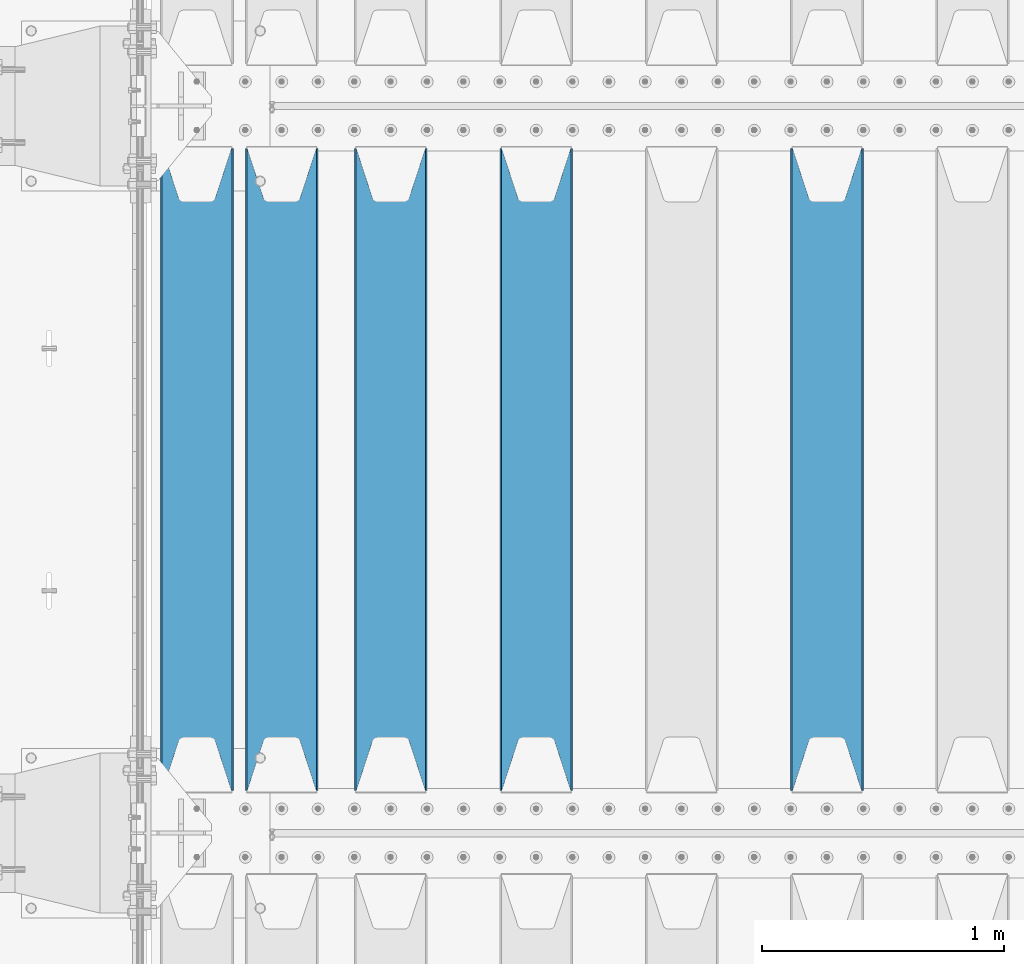
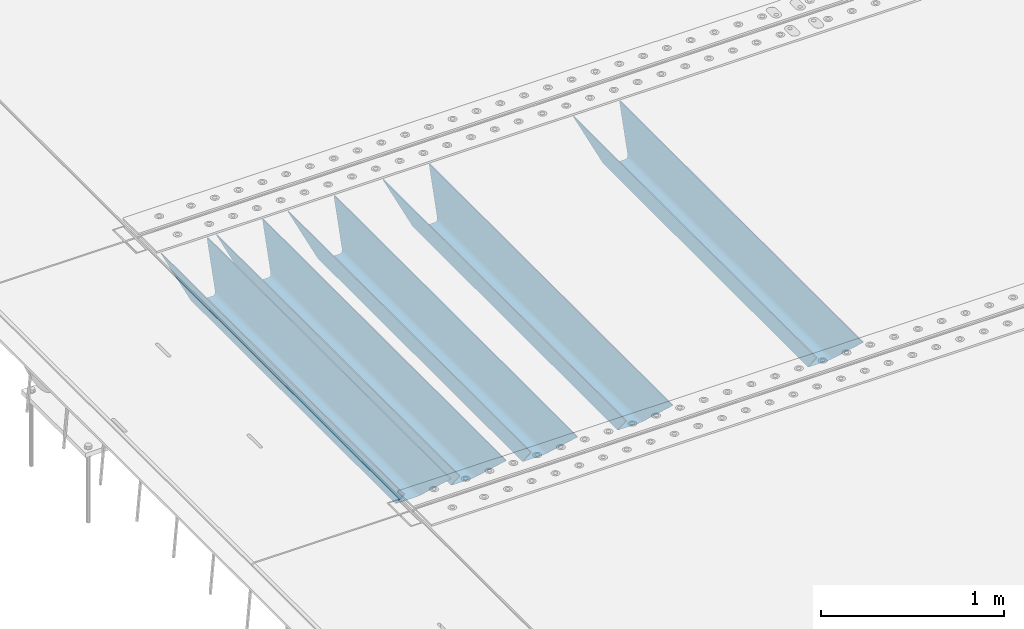
# One storey, part 102 of 240: 5 beams.
"""IFC2X3 building model written with IfcOpenShell, lengths in millimetres."""

import ifcopenshell
import ifcopenshell.guid

model = None  # the IFC model being written
_history = None  # IfcOwnerHistory: only IFC2X3 demands one
_inside = {}  # id of a spatial element -> (the spatial element, [elements in it])
_under = {}  # id of a project, library or spatial element -> (it, [spatial elements below it])
_declared = {}  # id of a project -> (the project, [libraries it declares])
_typed = {}  # id of a type object -> (the type object, [elements of that type])
_made_of = {}  # id of a material, layer set ... -> (it, [elements and type objects made of it])


def new_model(schema):
    """Start an empty IFC model of exactly this schema.

    Asked for "IFC4X3", IfcOpenShell would pick the latest addendum, in which some entities
    have other attributes; the version numbers below select the first issue.
    IFC2X3 requires an IfcOwnerHistory on every rooted entity: one is made here for all.
    """
    global model, _history
    if schema == "IFC4X3":
        model = ifcopenshell.file(schema_version=(4, 3, 0, 0))
    else:
        model = ifcopenshell.file(schema=schema)
    _inside.clear()
    _under.clear()
    _declared.clear()
    _typed.clear()
    _made_of.clear()
    _history = None
    if model.schema == "IFC2X3":
        org = make("IfcOrganization", Name="unknown")
        user = make(
            "IfcPersonAndOrganization",
            ThePerson=make("IfcPerson", FamilyName="unknown"),
            TheOrganization=org,
        )
        app = make(
            "IfcApplication",
            ApplicationDeveloper=org,
            Version="unknown",
            ApplicationFullName="unknown",
            ApplicationIdentifier="unknown",
        )
        _history = make(
            "IfcOwnerHistory",
            OwningUser=user,
            OwningApplication=app,
            ChangeAction="ADDED",
            CreationDate=0,
        )
    return model


def make(cls, **values):
    """One entity of the class cls with the attributes given. An attribute that is None is left unset."""
    return model.create_entity(
        cls, **{name: value for name, value in values.items() if value is not None}
    )


def rooted(cls, **values):
    """An entity with a GlobalId (a new one), such as an element, a storey or a relation."""
    return make(cls, GlobalId=ifcopenshell.guid.new(), OwnerHistory=_history, **values)


def si_unit(unit_type, name, prefix=None):
    """IfcSIUnit, for example si_unit("LENGTHUNIT", "METRE", prefix="MILLI")."""
    return make("IfcSIUnit", UnitType=unit_type, Prefix=prefix, Name=name)


def assignment(units):
    """IfcUnitAssignment: the units of a project."""
    return None if units is None else make("IfcUnitAssignment", Units=units)


def point(xyz):
    """IfcCartesianPoint."""
    return None if xyz is None else make("IfcCartesianPoint", Coordinates=xyz)


def direction(xyz):
    """IfcDirection."""
    return None if xyz is None else make("IfcDirection", DirectionRatios=xyz)


def frame(location, z_axis=None, x_axis=None):
    """IfcAxis2Placement3D, a coordinate frame: its origin and axes. An axis left out is left unset."""
    return make(
        "IfcAxis2Placement3D",
        Location=point(location),
        Axis=direction(z_axis),
        RefDirection=direction(x_axis),
    )


def origin_with_axes():
    """The frame at (0, 0, 0) with the z axis (0, 0, 1) and the x axis (1, 0, 0) written out."""
    return frame((0.0, 0.0, 0.0), z_axis=(0.0, 0.0, 1.0), x_axis=(1.0, 0.0, 0.0))


def place(relative_to, where):
    """IfcLocalPlacement: puts the frame where relative to a parent placement (None: the world)."""
    return make(
        "IfcLocalPlacement", PlacementRelTo=relative_to, RelativePlacement=where
    )


def context(
    kind, dimensions, precision=None, world=None, true_north=None, identifier=None
):
    """IfcGeometricRepresentationContext, for example the 3D "Model" context."""
    return make(
        "IfcGeometricRepresentationContext",
        ContextIdentifier=identifier,
        ContextType=kind,
        CoordinateSpaceDimension=dimensions,
        Precision=precision,
        WorldCoordinateSystem=world,
        TrueNorth=true_north,
    )


def subcontext(parent, identifier, kind, view, scale=None):
    """IfcGeometricRepresentationSubContext, for example "Body" below "Model"."""
    return make(
        "IfcGeometricRepresentationSubContext",
        ContextIdentifier=identifier,
        ContextType=kind,
        ParentContext=parent,
        TargetScale=scale,
        TargetView=view,
    )


def project(units=None, contexts=None):
    """IfcProject with its units and contexts."""
    return rooted(
        "IfcProject",
        Name="project",
        RepresentationContexts=contexts,
        UnitsInContext=assignment(units),
    )


def spatial(cls, under=None, at=None, **own):
    """A site, building, storey or space (cls), placed at a placement, below another one or the project."""
    s = rooted(cls, ObjectPlacement=at, **own)
    if under is not None:
        _under.setdefault(under.id(), (under, []))[1].append(s)
    return s


def faces_of(points, faces, orient=None, outer=None):
    """IfcFace entities. A face is a list of loops; a loop is a list of indices into points, from 0.

    orient and outer hold one flag for each loop. By default every Orientation is true, the
    first loop of a face is its IfcFaceOuterBound and the others are IfcFaceBound.
    """
    made = []
    for i, loops in enumerate(faces):
        bounds = []
        for j, loop in enumerate(loops):
            is_outer = j == 0 if outer is None else outer[i][j]
            bounds.append(
                make(
                    "IfcFaceOuterBound" if is_outer else "IfcFaceBound",
                    Bound=make("IfcPolyLoop", Polygon=[points[k] for k in loop]),
                    Orientation=True if orient is None else orient[i][j],
                )
            )
        made.append(make("IfcFace", Bounds=bounds))
    return made


def faceted_brep(points, faces, orient=None, outer=None, voids=None):
    """IfcFacetedBrep: a solid bounded by flat faces; with voids (closed shells), ...WithVoids."""
    shared = [point(p) for p in points]
    hull = make("IfcClosedShell", CfsFaces=faces_of(shared, faces, orient, outer))
    if voids is None:
        return make("IfcFacetedBrep", Outer=hull)
    return make(
        "IfcFacetedBrepWithVoids",
        Outer=hull,
        Voids=[
            make(cls, CfsFaces=faces_of(shared, fs, o, b)) for cls, fs, o, b in voids
        ],
    )


def shape(context_of_items, identifier, shape_type, items):
    """IfcShapeRepresentation: the items that make up one representation, for example the "Body"."""
    return make(
        "IfcShapeRepresentation",
        ContextOfItems=context_of_items,
        RepresentationIdentifier=identifier,
        RepresentationType=shape_type,
        Items=items,
    )


def material(Name=None, Category=None):
    """IfcMaterial."""
    return make("IfcMaterial", Name=Name, Category=Category)


def made_of(thing, what):
    """Note that an element or type object is made of a material, layer set ...; save() writes the relation."""
    if what is not None:
        _made_of.setdefault(what.id(), (what, []))[1].append(thing)
    return thing


def type_object(cls, material=None, **own):
    """A type object (cls), such as IfcWallType, which elements share."""
    return made_of(rooted(cls, **own), material)


def element(
    cls,
    number,
    at=None,
    inside=None,
    cuts=None,
    type_object=None,
    material=None,
    context=None,
    identifier="Body",
    shape_type=None,
    held_by="IfcProductDefinitionShape",
    body=None,
    shapes=None,
    **own,
):
    """One element of the class cls, such as IfcWall. Its Tag is "e" and its number.

    at: its placement. inside: the storey or other place that contains it. cuts: it is an
    opening in that element (IfcRelVoidsElement). A single representation is given by context,
    identifier, shape_type and body (its items); several are given by shapes. held_by: the class
    of the entity that holds the representations. save() writes the other relations.
    """
    e = rooted(cls, Tag="e%d" % number, ObjectPlacement=at, **own)
    if body is not None:
        shapes = [shape(context, identifier, shape_type, body)]
    if shapes is not None:
        e.Representation = make(held_by, Representations=shapes)
    if inside is not None:
        _inside.setdefault(inside.id(), (inside, []))[1].append(e)
    if cuts is not None:
        rooted(
            "IfcRelVoidsElement", RelatingBuildingElement=cuts, RelatedOpeningElement=e
        )
    if type_object is not None:
        _typed.setdefault(type_object.id(), (type_object, []))[1].append(e)
    return made_of(e, material)


def aggregate(whole, parts):
    """IfcRelAggregates: a whole, such as a stair, and the parts it consists of."""
    return rooted("IfcRelAggregates", RelatingObject=whole, RelatedObjects=parts)


def save(model, path):
    """Write the relations noted so far, then the file.

    IfcRelAggregates (storeys below a building ...), IfcRelContainedInSpatialStructure (elements
    in a storey), IfcRelDefinesByType, IfcRelAssociatesMaterial and IfcRelDeclares: one each for
    every whole, place, type object, material and project.
    """
    for whole, parts in _under.values():
        aggregate(whole, parts)
    for where, things in _inside.values():
        rooted(
            "IfcRelContainedInSpatialStructure",
            RelatedElements=things,
            RelatingStructure=where,
        )
    for kind, things in _typed.values():
        rooted("IfcRelDefinesByType", RelatedObjects=things, RelatingType=kind)
    for what, things in _made_of.values():
        rooted("IfcRelAssociatesMaterial", RelatedObjects=things, RelatingMaterial=what)
    for by, libraries in _declared.values():
        rooted("IfcRelDeclares", RelatingContext=by, RelatedDefinitions=libraries)
    model.write(path)


model = new_model("IFC2X3")

# Units and contexts
model_context = context("Model", 3, precision=1e-05, world=origin_with_axes())
body_context = subcontext(model_context, "Body", "Model", "MODEL_VIEW")
ifc_project = project(units=[si_unit("LENGTHUNIT", "METRE", prefix="MILLI"), si_unit("AREAUNIT", "SQUARE_METRE"), si_unit("VOLUMEUNIT", "CUBIC_METRE"), si_unit("MASSUNIT", "GRAM", prefix="KILO"), si_unit("TIMEUNIT", "SECOND"), si_unit("PLANEANGLEUNIT", "RADIAN"), si_unit("SOLIDANGLEUNIT", "STERADIAN"), si_unit("THERMODYNAMICTEMPERATUREUNIT", "DEGREE_CELSIUS"), si_unit("LUMINOUSINTENSITYUNIT", "LUMEN")], contexts=[model_context])

# Site, building, storey
site_placement = place(None, origin_with_axes())
site = spatial("IfcSite", under=ifc_project, at=site_placement, CompositionType="ELEMENT")
building_placement = place(site_placement, origin_with_axes())
building = spatial("IfcBuilding", under=site, at=building_placement, Name="Standard", CompositionType="ELEMENT")
storey_placement = place(building_placement, origin_with_axes())
storey = spatial("IfcBuildingStorey", under=building, at=storey_placement, Name="Undefined", CompositionType="ELEMENT", Elevation=0.0)

# Beams
ifc_material = material(Name="STEEL/S355N")
beam_type = type_object("IfcBeamType", PredefinedType="NOTDEFINED")
beam_1_placement = place(storey_placement, frame((45250.0, 27175.0, -115.0), z_axis=(0.0, 0.0, 1.0), x_axis=(0.0, 1.0, 0.0)))
element("IfcBeam", 1, at=beam_1_placement, inside=storey, type_object=beam_type, material=ifc_material, context=body_context, shape_type="Brep", body=[
    faceted_brep([(0.0, 150.0, 115.0), (0.0, 143.690000000002, 115.0), (2650.00000000297, 143.690000000002, 115.0), (2650.00000000297, 150.0, 115.0), (2650.00000000297, 142.059565218406, 110.000000003094), (2650.00000000297, 148.369565218403, 110.000000003094), (2441.90079219209, -80.1103600731149, -98.0992078077845), (2437.7588105432, -77.5672621345584, -102.241189456673), (2434.06523489747, -74.4080125315522, -105.934765102404), (2430.9108609509, -70.7102721255724, -109.089139048974), (2428.37322971128, -66.5649389910031, -111.626770288588), (2426.51472138055, -62.0739139532889, -113.485278619323), (2425.38102192092, -57.3475956567636, -114.618978078955), (2424.99999999987, -52.5021667386536, -115.0), (2424.99999999987, 52.5021667386536, -115.0), (2425.38102192092, 57.3475956567636, -114.618978078955), (2426.51472138055, 62.0739139532889, -113.485278619323), (2428.37322971128, 66.5649389910031, -111.626770288588), (2430.9108609509, 70.7102721255724, -109.089139048974), (2434.06523489747, 74.4080125315522, -105.934765102404), (2437.7588105432, 77.5672621345584, -102.241189456673), (2441.90079219209, 80.1103600731149, -98.0992078077846), (2446.38936140512, 81.9747917625791, -93.6106385947584), (2448.2494850041, 76.2713538057287, -91.7505149957729), (2444.62967112263, 74.76777986261, -95.3703288772456), (2441.28936334127, 72.7168944282894, -98.710636658607), (2438.31067330439, 70.1691124903809, -101.689326695487), (2435.76682334748, 67.1870637758839, -104.233176652398), (2433.72034654134, 63.8440531834931, -106.279653458539), (2432.22154950042, 60.2222587982324, -107.778450499454), (2431.30727574265, 56.4107117849126, -108.692724257221), (2430.99999999987, 52.5031078186876, -109.0), (2430.99999999987, -52.5031078186876, -109.0), (2431.30727574265, -56.4107117849126, -108.692724257221), (2432.22154950042, -60.2222587982324, -107.778450499454), (2433.72034654134, -63.8440531834931, -106.279653458539), (2435.76682334748, -67.1870637758839, -104.233176652398), (2438.31067330439, -70.1691124903809, -101.689326695487), (2441.28936334127, -72.7168944282894, -98.7106366586071), (2444.62967112263, -74.76777986261, -95.3703288772457), (2448.2494850041, -76.2713538057287, -91.7505149957729), (2650.00000000297, -142.059565218406, 110.000000003094), (2650.00000000297, -148.369565218403, 110.000000003094), (2446.38936140512, -81.9747917625791, -93.6106385947584), (2650.00000000297, -143.690000000002, 115.0), (2650.00000000297, -150.0, 115.0), (0.0, -143.690000000002, 115.0), (0.0, -150.0, 115.0), (0.0, -148.369565218258, 110.000000002667), (203.610638597427, -81.9747917625791, -93.6106385947584), (208.09920781045, -80.1103600731149, -98.0992078077845), (212.241189459342, -77.5672621345584, -102.241189456673), (215.93476510507, -74.4080125315522, -105.934765102404), (219.089139051641, -70.7102721255724, -109.089139048974), (221.626770291256, -66.5649389910031, -111.626770288588), (223.485278621989, -62.0739139532889, -113.485278619323), (224.618978081624, -57.3475956567636, -114.618978078955), (225.000000002663, -52.5021667386536, -115.0), (225.000000002663, 52.5021667386536, -115.0), (224.618978081624, 57.3475956567636, -114.618978078955), (223.485278621989, 62.0739139532889, -113.485278619323), (221.626770291256, 66.5649389910031, -111.626770288588), (219.089139051641, 70.7102721255724, -109.089139048974), (215.93476510507, 74.4080125315522, -105.934765102404), (212.241189459342, 77.5672621345584, -102.241189456673), (208.09920781045, 80.1103600731149, -98.0992078077846), (203.610638597427, 81.9747917625791, -93.6106385947584), (0.0, 148.369565218258, 110.000000002667), (0.0, 142.05956521826, 110.000000002667), (201.750514998439, 76.2713538057287, -91.7505149957729), (205.370328879908, 74.76777986261, -95.3703288772456), (208.710636661275, 72.7168944282894, -98.710636658607), (211.689326698153, 70.1691124903809, -101.689326695487), (214.233176655063, 67.1870637758839, -104.233176652398), (216.279653461206, 63.8440531834931, -106.279653458539), (217.778450502123, 60.2222587982324, -107.778450499454), (218.692724259887, 56.4107117849126, -108.692724257221), (219.000000002667, 52.5031078186876, -109.0), (219.000000002667, -52.5031078186876, -109.0), (218.692724259887, -56.4107117849126, -108.692724257221), (217.778450502123, -60.2222587982324, -107.778450499454), (216.279653461206, -63.8440531834931, -106.279653458539), (214.233176655063, -67.1870637758839, -104.233176652398), (211.689326698153, -70.1691124903809, -101.689326695487), (208.710636661275, -72.7168944282894, -98.7106366586071), (205.370328879915, -74.76777986261, -95.3703288772457), (201.750514998439, -76.2713538057287, -91.7505149957729), (0.0, -142.05956521826, 110.000000002667)], [[[0, 1, 2, 3]], [[3, 2, 4, 5]], [[6, 7, 8, 9, 10, 11, 12, 13, 14, 15, 16, 17, 18, 19, 20, 21, 22, 5, 4, 23, 24, 25, 26, 27, 28, 29, 30, 31, 32, 33, 34, 35, 36, 37, 38, 39, 40, 41, 42, 43]], [[44, 45, 42, 41]], [[46, 47, 45, 44]], [[43, 42, 45, 47, 48, 49]], [[6, 43, 49, 50]], [[7, 6, 50, 51]], [[8, 7, 51, 52]], [[9, 8, 52, 53]], [[10, 9, 53, 54]], [[11, 10, 54, 55]], [[12, 11, 55, 56]], [[13, 12, 56, 57]], [[14, 13, 57, 58]], [[15, 14, 58, 59]], [[16, 15, 59, 60]], [[17, 16, 60, 61]], [[18, 17, 61, 62]], [[19, 18, 62, 63]], [[20, 19, 63, 64]], [[21, 20, 64, 65]], [[22, 21, 65, 66]], [[0, 3, 5, 22, 66, 67]], [[1, 0, 67, 68]], [[23, 4, 2, 1, 68, 69]], [[24, 23, 69, 70]], [[25, 24, 70, 71]], [[26, 25, 71, 72]], [[27, 26, 72, 73]], [[28, 27, 73, 74]], [[29, 28, 74, 75]], [[30, 29, 75, 76]], [[31, 30, 76, 77]], [[32, 31, 77, 78]], [[33, 32, 78, 79]], [[34, 33, 79, 80]], [[35, 34, 80, 81]], [[36, 35, 81, 82]], [[37, 36, 82, 83]], [[38, 37, 83, 84]], [[39, 38, 84, 85]], [[40, 39, 85, 86]], [[46, 44, 41, 40, 86, 87]], [[47, 46, 87, 48]], [[86, 85, 84, 83, 82, 81, 80, 79, 78, 77, 76, 75, 74, 73, 72, 71, 70, 69, 68, 67, 66, 65, 64, 63, 62, 61, 60, 59, 58, 57, 56, 55, 54, 53, 52, 51, 50, 49, 48, 87]]]),
])
beam_2_placement = place(storey_placement, frame((44050.0, 27175.0, -115.0), z_axis=(0.0, 0.0, 1.0), x_axis=(0.0, 1.0, 0.0)))
element("IfcBeam", 2, at=beam_2_placement, inside=storey, type_object=beam_type, material=ifc_material, context=body_context, shape_type="Brep", body=[
    faceted_brep([(0.0, 150.0, 115.0), (0.0, 143.690000000002, 115.0), (2650.00000000297, 143.690000000002, 115.0), (2650.00000000297, 150.0, 115.0), (2650.00000000297, 142.059565218406, 110.000000003094), (2650.00000000297, 148.369565218403, 110.000000003094), (2441.90079219209, -80.1103600731149, -98.0992078077845), (2437.7588105432, -77.5672621345584, -102.241189456673), (2434.06523489747, -74.4080125315522, -105.934765102404), (2430.9108609509, -70.7102721255724, -109.089139048974), (2428.37322971128, -66.5649389910031, -111.626770288588), (2426.51472138055, -62.0739139532889, -113.485278619323), (2425.38102192092, -57.3475956567636, -114.618978078955), (2424.99999999987, -52.5021667386536, -115.0), (2424.99999999987, 52.5021667386536, -115.0), (2425.38102192092, 57.3475956567636, -114.618978078955), (2426.51472138055, 62.0739139532889, -113.485278619323), (2428.37322971128, 66.5649389910031, -111.626770288588), (2430.9108609509, 70.7102721255724, -109.089139048974), (2434.06523489747, 74.4080125315522, -105.934765102404), (2437.7588105432, 77.5672621345584, -102.241189456673), (2441.90079219209, 80.1103600731149, -98.0992078077846), (2446.38936140512, 81.9747917625791, -93.6106385947584), (2448.2494850041, 76.2713538057287, -91.7505149957729), (2444.62967112263, 74.76777986261, -95.3703288772456), (2441.28936334127, 72.7168944282894, -98.710636658607), (2438.31067330439, 70.1691124903809, -101.689326695487), (2435.76682334748, 67.1870637758839, -104.233176652398), (2433.72034654134, 63.8440531834931, -106.279653458539), (2432.22154950042, 60.2222587982324, -107.778450499454), (2431.30727574265, 56.4107117849126, -108.692724257221), (2430.99999999987, 52.5031078186876, -109.0), (2430.99999999987, -52.5031078186876, -109.0), (2431.30727574265, -56.4107117849126, -108.692724257221), (2432.22154950042, -60.2222587982324, -107.778450499454), (2433.72034654134, -63.8440531834931, -106.279653458539), (2435.76682334748, -67.1870637758839, -104.233176652398), (2438.31067330439, -70.1691124903809, -101.689326695487), (2441.28936334127, -72.7168944282894, -98.7106366586071), (2444.62967112263, -74.76777986261, -95.3703288772457), (2448.2494850041, -76.2713538057287, -91.7505149957729), (2650.00000000297, -142.059565218406, 110.000000003094), (2650.00000000297, -148.369565218403, 110.000000003094), (2446.38936140512, -81.9747917625791, -93.6106385947584), (2650.00000000297, -143.690000000002, 115.0), (2650.00000000297, -150.0, 115.0), (0.0, -143.690000000002, 115.0), (0.0, -150.0, 115.0), (0.0, -148.369565218258, 110.000000002667), (203.610638597427, -81.9747917625791, -93.6106385947584), (208.09920781045, -80.1103600731149, -98.0992078077845), (212.241189459342, -77.5672621345584, -102.241189456673), (215.93476510507, -74.4080125315522, -105.934765102404), (219.089139051641, -70.7102721255724, -109.089139048974), (221.626770291256, -66.5649389910031, -111.626770288588), (223.485278621989, -62.0739139532889, -113.485278619323), (224.618978081624, -57.3475956567636, -114.618978078955), (225.000000002663, -52.5021667386536, -115.0), (225.000000002663, 52.5021667386536, -115.0), (224.618978081624, 57.3475956567636, -114.618978078955), (223.485278621989, 62.0739139532889, -113.485278619323), (221.626770291256, 66.5649389910031, -111.626770288588), (219.089139051641, 70.7102721255724, -109.089139048974), (215.93476510507, 74.4080125315522, -105.934765102404), (212.241189459342, 77.5672621345584, -102.241189456673), (208.09920781045, 80.1103600731149, -98.0992078077846), (203.610638597427, 81.9747917625791, -93.6106385947584), (0.0, 148.369565218258, 110.000000002667), (0.0, 142.05956521826, 110.000000002667), (201.750514998439, 76.2713538057287, -91.7505149957729), (205.370328879908, 74.76777986261, -95.3703288772456), (208.710636661275, 72.7168944282894, -98.710636658607), (211.689326698153, 70.1691124903809, -101.689326695487), (214.233176655063, 67.1870637758839, -104.233176652398), (216.279653461206, 63.8440531834931, -106.279653458539), (217.778450502123, 60.2222587982324, -107.778450499454), (218.692724259887, 56.4107117849126, -108.692724257221), (219.000000002667, 52.5031078186876, -109.0), (219.000000002667, -52.5031078186876, -109.0), (218.692724259887, -56.4107117849126, -108.692724257221), (217.778450502123, -60.2222587982324, -107.778450499454), (216.279653461206, -63.8440531834931, -106.279653458539), (214.233176655063, -67.1870637758839, -104.233176652398), (211.689326698153, -70.1691124903809, -101.689326695487), (208.710636661275, -72.7168944282894, -98.7106366586071), (205.370328879915, -74.76777986261, -95.3703288772457), (201.750514998439, -76.2713538057287, -91.7505149957729), (0.0, -142.05956521826, 110.000000002667)], [[[0, 1, 2, 3]], [[3, 2, 4, 5]], [[6, 7, 8, 9, 10, 11, 12, 13, 14, 15, 16, 17, 18, 19, 20, 21, 22, 5, 4, 23, 24, 25, 26, 27, 28, 29, 30, 31, 32, 33, 34, 35, 36, 37, 38, 39, 40, 41, 42, 43]], [[44, 45, 42, 41]], [[46, 47, 45, 44]], [[43, 42, 45, 47, 48, 49]], [[6, 43, 49, 50]], [[7, 6, 50, 51]], [[8, 7, 51, 52]], [[9, 8, 52, 53]], [[10, 9, 53, 54]], [[11, 10, 54, 55]], [[12, 11, 55, 56]], [[13, 12, 56, 57]], [[14, 13, 57, 58]], [[15, 14, 58, 59]], [[16, 15, 59, 60]], [[17, 16, 60, 61]], [[18, 17, 61, 62]], [[19, 18, 62, 63]], [[20, 19, 63, 64]], [[21, 20, 64, 65]], [[22, 21, 65, 66]], [[0, 3, 5, 22, 66, 67]], [[1, 0, 67, 68]], [[23, 4, 2, 1, 68, 69]], [[24, 23, 69, 70]], [[25, 24, 70, 71]], [[26, 25, 71, 72]], [[27, 26, 72, 73]], [[28, 27, 73, 74]], [[29, 28, 74, 75]], [[30, 29, 75, 76]], [[31, 30, 76, 77]], [[32, 31, 77, 78]], [[33, 32, 78, 79]], [[34, 33, 79, 80]], [[35, 34, 80, 81]], [[36, 35, 81, 82]], [[37, 36, 82, 83]], [[38, 37, 83, 84]], [[39, 38, 84, 85]], [[40, 39, 85, 86]], [[46, 44, 41, 40, 86, 87]], [[47, 46, 87, 48]], [[86, 85, 84, 83, 82, 81, 80, 79, 78, 77, 76, 75, 74, 73, 72, 71, 70, 69, 68, 67, 66, 65, 64, 63, 62, 61, 60, 59, 58, 57, 56, 55, 54, 53, 52, 51, 50, 49, 48, 87]]]),
])
beam_3_placement = place(storey_placement, frame((43450.0, 27175.0, -115.0), z_axis=(0.0, 0.0, 1.0), x_axis=(0.0, 1.0, 0.0)))
element("IfcBeam", 3, at=beam_3_placement, inside=storey, type_object=beam_type, material=ifc_material, context=body_context, shape_type="Brep", body=[
    faceted_brep([(0.0, 150.0, 115.0), (0.0, 143.690000000002, 115.0), (2650.00000000297, 143.690000000002, 115.0), (2650.00000000297, 150.0, 115.0), (2650.00000000297, 142.059565218406, 110.000000003094), (2650.00000000297, 148.369565218403, 110.000000003094), (2441.90079219209, -80.1103600731149, -98.0992078077845), (2437.7588105432, -77.5672621345584, -102.241189456673), (2434.06523489747, -74.4080125315522, -105.934765102404), (2430.9108609509, -70.7102721255724, -109.089139048974), (2428.37322971128, -66.5649389910031, -111.626770288588), (2426.51472138055, -62.0739139532889, -113.485278619323), (2425.38102192092, -57.3475956567636, -114.618978078955), (2424.99999999987, -52.5021667386536, -115.0), (2424.99999999987, 52.5021667386536, -115.0), (2425.38102192092, 57.3475956567636, -114.618978078955), (2426.51472138055, 62.0739139532889, -113.485278619323), (2428.37322971128, 66.5649389910031, -111.626770288588), (2430.9108609509, 70.7102721255724, -109.089139048974), (2434.06523489747, 74.4080125315522, -105.934765102404), (2437.7588105432, 77.5672621345584, -102.241189456673), (2441.90079219209, 80.1103600731149, -98.0992078077846), (2446.38936140512, 81.9747917625791, -93.6106385947584), (2448.2494850041, 76.2713538057287, -91.7505149957729), (2444.62967112263, 74.76777986261, -95.3703288772456), (2441.28936334127, 72.7168944282894, -98.710636658607), (2438.31067330439, 70.1691124903809, -101.689326695487), (2435.76682334748, 67.1870637758839, -104.233176652398), (2433.72034654134, 63.8440531834931, -106.279653458539), (2432.22154950042, 60.2222587982324, -107.778450499454), (2431.30727574265, 56.4107117849126, -108.692724257221), (2430.99999999987, 52.5031078186876, -109.0), (2430.99999999987, -52.5031078186876, -109.0), (2431.30727574265, -56.4107117849126, -108.692724257221), (2432.22154950042, -60.2222587982324, -107.778450499454), (2433.72034654134, -63.8440531834931, -106.279653458539), (2435.76682334748, -67.1870637758839, -104.233176652398), (2438.31067330439, -70.1691124903809, -101.689326695487), (2441.28936334127, -72.7168944282894, -98.7106366586071), (2444.62967112263, -74.76777986261, -95.3703288772457), (2448.2494850041, -76.2713538057287, -91.7505149957729), (2650.00000000297, -142.059565218406, 110.000000003094), (2650.00000000297, -148.369565218403, 110.000000003094), (2446.38936140512, -81.9747917625791, -93.6106385947584), (2650.00000000297, -143.690000000002, 115.0), (2650.00000000297, -150.0, 115.0), (0.0, -143.690000000002, 115.0), (0.0, -150.0, 115.0), (0.0, -148.369565218258, 110.000000002667), (203.610638597427, -81.9747917625791, -93.6106385947584), (208.09920781045, -80.1103600731149, -98.0992078077845), (212.241189459342, -77.5672621345584, -102.241189456673), (215.93476510507, -74.4080125315522, -105.934765102404), (219.089139051641, -70.7102721255724, -109.089139048974), (221.626770291256, -66.5649389910031, -111.626770288588), (223.485278621989, -62.0739139532889, -113.485278619323), (224.618978081624, -57.3475956567636, -114.618978078955), (225.000000002663, -52.5021667386536, -115.0), (225.000000002663, 52.5021667386536, -115.0), (224.618978081624, 57.3475956567636, -114.618978078955), (223.485278621989, 62.0739139532889, -113.485278619323), (221.626770291256, 66.5649389910031, -111.626770288588), (219.089139051641, 70.7102721255724, -109.089139048974), (215.93476510507, 74.4080125315522, -105.934765102404), (212.241189459342, 77.5672621345584, -102.241189456673), (208.09920781045, 80.1103600731149, -98.0992078077846), (203.610638597427, 81.9747917625791, -93.6106385947584), (0.0, 148.369565218258, 110.000000002667), (0.0, 142.05956521826, 110.000000002667), (201.750514998439, 76.2713538057287, -91.7505149957729), (205.370328879908, 74.76777986261, -95.3703288772456), (208.710636661275, 72.7168944282894, -98.710636658607), (211.689326698153, 70.1691124903809, -101.689326695487), (214.233176655063, 67.1870637758839, -104.233176652398), (216.279653461206, 63.8440531834931, -106.279653458539), (217.778450502123, 60.2222587982324, -107.778450499454), (218.692724259887, 56.4107117849126, -108.692724257221), (219.000000002667, 52.5031078186876, -109.0), (219.000000002667, -52.5031078186876, -109.0), (218.692724259887, -56.4107117849126, -108.692724257221), (217.778450502123, -60.2222587982324, -107.778450499454), (216.279653461206, -63.8440531834931, -106.279653458539), (214.233176655063, -67.1870637758839, -104.233176652398), (211.689326698153, -70.1691124903809, -101.689326695487), (208.710636661275, -72.7168944282894, -98.7106366586071), (205.370328879915, -74.76777986261, -95.3703288772457), (201.750514998439, -76.2713538057287, -91.7505149957729), (0.0, -142.05956521826, 110.000000002667)], [[[0, 1, 2, 3]], [[3, 2, 4, 5]], [[6, 7, 8, 9, 10, 11, 12, 13, 14, 15, 16, 17, 18, 19, 20, 21, 22, 5, 4, 23, 24, 25, 26, 27, 28, 29, 30, 31, 32, 33, 34, 35, 36, 37, 38, 39, 40, 41, 42, 43]], [[44, 45, 42, 41]], [[46, 47, 45, 44]], [[43, 42, 45, 47, 48, 49]], [[6, 43, 49, 50]], [[7, 6, 50, 51]], [[8, 7, 51, 52]], [[9, 8, 52, 53]], [[10, 9, 53, 54]], [[11, 10, 54, 55]], [[12, 11, 55, 56]], [[13, 12, 56, 57]], [[14, 13, 57, 58]], [[15, 14, 58, 59]], [[16, 15, 59, 60]], [[17, 16, 60, 61]], [[18, 17, 61, 62]], [[19, 18, 62, 63]], [[20, 19, 63, 64]], [[21, 20, 64, 65]], [[22, 21, 65, 66]], [[0, 3, 5, 22, 66, 67]], [[1, 0, 67, 68]], [[23, 4, 2, 1, 68, 69]], [[24, 23, 69, 70]], [[25, 24, 70, 71]], [[26, 25, 71, 72]], [[27, 26, 72, 73]], [[28, 27, 73, 74]], [[29, 28, 74, 75]], [[30, 29, 75, 76]], [[31, 30, 76, 77]], [[32, 31, 77, 78]], [[33, 32, 78, 79]], [[34, 33, 79, 80]], [[35, 34, 80, 81]], [[36, 35, 81, 82]], [[37, 36, 82, 83]], [[38, 37, 83, 84]], [[39, 38, 84, 85]], [[40, 39, 85, 86]], [[46, 44, 41, 40, 86, 87]], [[47, 46, 87, 48]], [[86, 85, 84, 83, 82, 81, 80, 79, 78, 77, 76, 75, 74, 73, 72, 71, 70, 69, 68, 67, 66, 65, 64, 63, 62, 61, 60, 59, 58, 57, 56, 55, 54, 53, 52, 51, 50, 49, 48, 87]]]),
])
beam_4_placement = place(storey_placement, frame((43000.0, 27175.0, -115.0), z_axis=(0.0, 0.0, 1.0), x_axis=(0.0, 1.0, 0.0)))
element("IfcBeam", 4, at=beam_4_placement, inside=storey, type_object=beam_type, material=ifc_material, context=body_context, shape_type="Brep", body=[
    faceted_brep([(0.0, 150.0, 115.0), (0.0, 143.690000000002, 115.0), (2650.00000000297, 143.690000000002, 115.0), (2650.00000000297, 150.0, 115.0), (2650.00000000297, 142.059565218406, 110.000000003094), (2650.00000000297, 148.369565218403, 110.000000003094), (2441.90079219209, -80.1103600731149, -98.0992078077845), (2437.7588105432, -77.5672621345584, -102.241189456673), (2434.06523489747, -74.4080125315522, -105.934765102404), (2430.9108609509, -70.7102721255724, -109.089139048974), (2428.37322971128, -66.5649389910031, -111.626770288588), (2426.51472138055, -62.0739139532889, -113.485278619323), (2425.38102192092, -57.3475956567636, -114.618978078955), (2424.99999999987, -52.5021667386536, -115.0), (2424.99999999987, 52.5021667386536, -115.0), (2425.38102192092, 57.3475956567636, -114.618978078955), (2426.51472138055, 62.0739139532889, -113.485278619323), (2428.37322971128, 66.5649389910031, -111.626770288588), (2430.9108609509, 70.7102721255724, -109.089139048974), (2434.06523489747, 74.4080125315522, -105.934765102404), (2437.7588105432, 77.5672621345584, -102.241189456673), (2441.90079219209, 80.1103600731149, -98.0992078077846), (2446.38936140512, 81.9747917625791, -93.6106385947584), (2448.2494850041, 76.2713538057287, -91.7505149957729), (2444.62967112263, 74.76777986261, -95.3703288772456), (2441.28936334127, 72.7168944282894, -98.710636658607), (2438.31067330439, 70.1691124903809, -101.689326695487), (2435.76682334748, 67.1870637758839, -104.233176652398), (2433.72034654134, 63.8440531834931, -106.279653458539), (2432.22154950042, 60.2222587982324, -107.778450499454), (2431.30727574265, 56.4107117849126, -108.692724257221), (2430.99999999987, 52.5031078186876, -109.0), (2430.99999999987, -52.5031078186876, -109.0), (2431.30727574265, -56.4107117849126, -108.692724257221), (2432.22154950042, -60.2222587982324, -107.778450499454), (2433.72034654134, -63.8440531834931, -106.279653458539), (2435.76682334748, -67.1870637758839, -104.233176652398), (2438.31067330439, -70.1691124903809, -101.689326695487), (2441.28936334127, -72.7168944282894, -98.7106366586071), (2444.62967112263, -74.76777986261, -95.3703288772457), (2448.2494850041, -76.2713538057287, -91.7505149957729), (2650.00000000297, -142.059565218406, 110.000000003094), (2650.00000000297, -148.369565218403, 110.000000003094), (2446.38936140512, -81.9747917625791, -93.6106385947584), (2650.00000000297, -143.690000000002, 115.0), (2650.00000000297, -150.0, 115.0), (0.0, -143.690000000002, 115.0), (0.0, -150.0, 115.0), (0.0, -148.369565218258, 110.000000002667), (203.610638597427, -81.9747917625791, -93.6106385947584), (208.09920781045, -80.1103600731149, -98.0992078077845), (212.241189459342, -77.5672621345584, -102.241189456673), (215.93476510507, -74.4080125315522, -105.934765102404), (219.089139051641, -70.7102721255724, -109.089139048974), (221.626770291256, -66.5649389910031, -111.626770288588), (223.485278621989, -62.0739139532889, -113.485278619323), (224.618978081624, -57.3475956567636, -114.618978078955), (225.000000002663, -52.5021667386536, -115.0), (225.000000002663, 52.5021667386536, -115.0), (224.618978081624, 57.3475956567636, -114.618978078955), (223.485278621989, 62.0739139532889, -113.485278619323), (221.626770291256, 66.5649389910031, -111.626770288588), (219.089139051641, 70.7102721255724, -109.089139048974), (215.93476510507, 74.4080125315522, -105.934765102404), (212.241189459342, 77.5672621345584, -102.241189456673), (208.09920781045, 80.1103600731149, -98.0992078077846), (203.610638597427, 81.9747917625791, -93.6106385947584), (0.0, 148.369565218258, 110.000000002667), (0.0, 142.05956521826, 110.000000002667), (201.750514998439, 76.2713538057287, -91.7505149957729), (205.370328879908, 74.76777986261, -95.3703288772456), (208.710636661275, 72.7168944282894, -98.710636658607), (211.689326698153, 70.1691124903809, -101.689326695487), (214.233176655063, 67.1870637758839, -104.233176652398), (216.279653461206, 63.8440531834931, -106.279653458539), (217.778450502123, 60.2222587982324, -107.778450499454), (218.692724259887, 56.4107117849126, -108.692724257221), (219.000000002667, 52.5031078186876, -109.0), (219.000000002667, -52.5031078186876, -109.0), (218.692724259887, -56.4107117849126, -108.692724257221), (217.778450502123, -60.2222587982324, -107.778450499454), (216.279653461206, -63.8440531834931, -106.279653458539), (214.233176655063, -67.1870637758839, -104.233176652398), (211.689326698153, -70.1691124903809, -101.689326695487), (208.710636661275, -72.7168944282894, -98.7106366586071), (205.370328879915, -74.76777986261, -95.3703288772457), (201.750514998439, -76.2713538057287, -91.7505149957729), (0.0, -142.05956521826, 110.000000002667)], [[[0, 1, 2, 3]], [[3, 2, 4, 5]], [[6, 7, 8, 9, 10, 11, 12, 13, 14, 15, 16, 17, 18, 19, 20, 21, 22, 5, 4, 23, 24, 25, 26, 27, 28, 29, 30, 31, 32, 33, 34, 35, 36, 37, 38, 39, 40, 41, 42, 43]], [[44, 45, 42, 41]], [[46, 47, 45, 44]], [[43, 42, 45, 47, 48, 49]], [[6, 43, 49, 50]], [[7, 6, 50, 51]], [[8, 7, 51, 52]], [[9, 8, 52, 53]], [[10, 9, 53, 54]], [[11, 10, 54, 55]], [[12, 11, 55, 56]], [[13, 12, 56, 57]], [[14, 13, 57, 58]], [[15, 14, 58, 59]], [[16, 15, 59, 60]], [[17, 16, 60, 61]], [[18, 17, 61, 62]], [[19, 18, 62, 63]], [[20, 19, 63, 64]], [[21, 20, 64, 65]], [[22, 21, 65, 66]], [[0, 3, 5, 22, 66, 67]], [[1, 0, 67, 68]], [[23, 4, 2, 1, 68, 69]], [[24, 23, 69, 70]], [[25, 24, 70, 71]], [[26, 25, 71, 72]], [[27, 26, 72, 73]], [[28, 27, 73, 74]], [[29, 28, 74, 75]], [[30, 29, 75, 76]], [[31, 30, 76, 77]], [[32, 31, 77, 78]], [[33, 32, 78, 79]], [[34, 33, 79, 80]], [[35, 34, 80, 81]], [[36, 35, 81, 82]], [[37, 36, 82, 83]], [[38, 37, 83, 84]], [[39, 38, 84, 85]], [[40, 39, 85, 86]], [[46, 44, 41, 40, 86, 87]], [[47, 46, 87, 48]], [[86, 85, 84, 83, 82, 81, 80, 79, 78, 77, 76, 75, 74, 73, 72, 71, 70, 69, 68, 67, 66, 65, 64, 63, 62, 61, 60, 59, 58, 57, 56, 55, 54, 53, 52, 51, 50, 49, 48, 87]]]),
])
beam_5_placement = place(storey_placement, frame((42650.0, 27175.0, -115.0), z_axis=(0.0, 0.0, 1.0), x_axis=(0.0, 1.0, 0.0)))
element("IfcBeam", 5, at=beam_5_placement, inside=storey, type_object=beam_type, material=ifc_material, context=body_context, shape_type="Brep", body=[
    faceted_brep([(0.0, 150.0, 115.0), (0.0, 143.690000000002, 115.0), (2650.00000000297, 143.690000000002, 115.0), (2650.00000000297, 150.0, 115.0), (2650.00000000297, 142.059565218406, 110.000000003094), (2650.00000000297, 148.369565218403, 110.000000003094), (2441.90079219209, -80.1103600731149, -98.0992078077845), (2437.7588105432, -77.5672621345584, -102.241189456673), (2434.06523489747, -74.4080125315522, -105.934765102404), (2430.9108609509, -70.7102721255724, -109.089139048974), (2428.37322971128, -66.5649389910031, -111.626770288588), (2426.51472138055, -62.0739139532889, -113.485278619323), (2425.38102192092, -57.3475956567636, -114.618978078955), (2424.99999999987, -52.5021667386536, -115.0), (2424.99999999987, 52.5021667386536, -115.0), (2425.38102192092, 57.3475956567636, -114.618978078955), (2426.51472138055, 62.0739139532889, -113.485278619323), (2428.37322971128, 66.5649389910031, -111.626770288588), (2430.9108609509, 70.7102721255724, -109.089139048974), (2434.06523489747, 74.4080125315522, -105.934765102404), (2437.7588105432, 77.5672621345584, -102.241189456673), (2441.90079219209, 80.1103600731149, -98.0992078077846), (2446.38936140512, 81.9747917625791, -93.6106385947584), (2448.2494850041, 76.2713538057287, -91.7505149957729), (2444.62967112263, 74.76777986261, -95.3703288772456), (2441.28936334127, 72.7168944282894, -98.710636658607), (2438.31067330439, 70.1691124903809, -101.689326695487), (2435.76682334748, 67.1870637758839, -104.233176652398), (2433.72034654134, 63.8440531834931, -106.279653458539), (2432.22154950042, 60.2222587982324, -107.778450499454), (2431.30727574265, 56.4107117849126, -108.692724257221), (2430.99999999987, 52.5031078186876, -109.0), (2430.99999999987, -52.5031078186876, -109.0), (2431.30727574265, -56.4107117849126, -108.692724257221), (2432.22154950042, -60.2222587982324, -107.778450499454), (2433.72034654134, -63.8440531834931, -106.279653458539), (2435.76682334748, -67.1870637758839, -104.233176652398), (2438.31067330439, -70.1691124903809, -101.689326695487), (2441.28936334127, -72.7168944282894, -98.7106366586071), (2444.62967112263, -74.76777986261, -95.3703288772457), (2448.2494850041, -76.2713538057287, -91.7505149957729), (2650.00000000297, -142.059565218406, 110.000000003094), (2650.00000000297, -148.369565218403, 110.000000003094), (2446.38936140512, -81.9747917625791, -93.6106385947584), (2650.00000000297, -143.690000000002, 115.0), (2650.00000000297, -150.0, 115.0), (0.0, -143.690000000002, 115.0), (0.0, -150.0, 115.0), (0.0, -148.369565218258, 110.000000002667), (203.610638597427, -81.9747917625791, -93.6106385947584), (208.09920781045, -80.1103600731149, -98.0992078077845), (212.241189459342, -77.5672621345584, -102.241189456673), (215.93476510507, -74.4080125315522, -105.934765102404), (219.089139051641, -70.7102721255724, -109.089139048974), (221.626770291256, -66.5649389910031, -111.626770288588), (223.485278621989, -62.0739139532889, -113.485278619323), (224.618978081624, -57.3475956567636, -114.618978078955), (225.000000002663, -52.5021667386536, -115.0), (225.000000002663, 52.5021667386536, -115.0), (224.618978081624, 57.3475956567636, -114.618978078955), (223.485278621989, 62.0739139532889, -113.485278619323), (221.626770291256, 66.5649389910031, -111.626770288588), (219.089139051641, 70.7102721255724, -109.089139048974), (215.93476510507, 74.4080125315522, -105.934765102404), (212.241189459342, 77.5672621345584, -102.241189456673), (208.09920781045, 80.1103600731149, -98.0992078077846), (203.610638597427, 81.9747917625791, -93.6106385947584), (0.0, 148.369565218258, 110.000000002667), (0.0, 142.05956521826, 110.000000002667), (201.750514998439, 76.2713538057287, -91.7505149957729), (205.370328879908, 74.76777986261, -95.3703288772456), (208.710636661275, 72.7168944282894, -98.710636658607), (211.689326698153, 70.1691124903809, -101.689326695487), (214.233176655063, 67.1870637758839, -104.233176652398), (216.279653461206, 63.8440531834931, -106.279653458539), (217.778450502123, 60.2222587982324, -107.778450499454), (218.692724259887, 56.4107117849126, -108.692724257221), (219.000000002667, 52.5031078186876, -109.0), (219.000000002667, -52.5031078186876, -109.0), (218.692724259887, -56.4107117849126, -108.692724257221), (217.778450502123, -60.2222587982324, -107.778450499454), (216.279653461206, -63.8440531834931, -106.279653458539), (214.233176655063, -67.1870637758839, -104.233176652398), (211.689326698153, -70.1691124903809, -101.689326695487), (208.710636661275, -72.7168944282894, -98.7106366586071), (205.370328879915, -74.76777986261, -95.3703288772457), (201.750514998439, -76.2713538057287, -91.7505149957729), (0.0, -142.05956521826, 110.000000002667)], [[[0, 1, 2, 3]], [[3, 2, 4, 5]], [[6, 7, 8, 9, 10, 11, 12, 13, 14, 15, 16, 17, 18, 19, 20, 21, 22, 5, 4, 23, 24, 25, 26, 27, 28, 29, 30, 31, 32, 33, 34, 35, 36, 37, 38, 39, 40, 41, 42, 43]], [[44, 45, 42, 41]], [[46, 47, 45, 44]], [[43, 42, 45, 47, 48, 49]], [[6, 43, 49, 50]], [[7, 6, 50, 51]], [[8, 7, 51, 52]], [[9, 8, 52, 53]], [[10, 9, 53, 54]], [[11, 10, 54, 55]], [[12, 11, 55, 56]], [[13, 12, 56, 57]], [[14, 13, 57, 58]], [[15, 14, 58, 59]], [[16, 15, 59, 60]], [[17, 16, 60, 61]], [[18, 17, 61, 62]], [[19, 18, 62, 63]], [[20, 19, 63, 64]], [[21, 20, 64, 65]], [[22, 21, 65, 66]], [[0, 3, 5, 22, 66, 67]], [[1, 0, 67, 68]], [[23, 4, 2, 1, 68, 69]], [[24, 23, 69, 70]], [[25, 24, 70, 71]], [[26, 25, 71, 72]], [[27, 26, 72, 73]], [[28, 27, 73, 74]], [[29, 28, 74, 75]], [[30, 29, 75, 76]], [[31, 30, 76, 77]], [[32, 31, 77, 78]], [[33, 32, 78, 79]], [[34, 33, 79, 80]], [[35, 34, 80, 81]], [[36, 35, 81, 82]], [[37, 36, 82, 83]], [[38, 37, 83, 84]], [[39, 38, 84, 85]], [[40, 39, 85, 86]], [[46, 44, 41, 40, 86, 87]], [[47, 46, 87, 48]], [[86, 85, 84, 83, 82, 81, 80, 79, 78, 77, 76, 75, 74, 73, 72, 71, 70, 69, 68, 67, 66, 65, 64, 63, 62, 61, 60, 59, 58, 57, 56, 55, 54, 53, 52, 51, 50, 49, 48, 87]]]),
])

save(model, "model.ifc")
